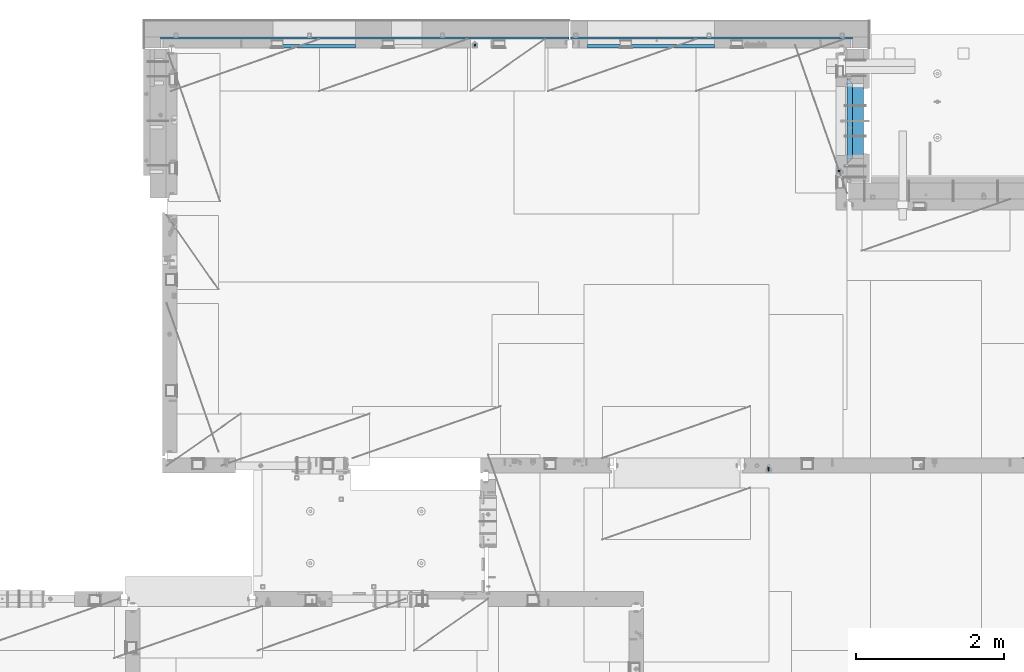
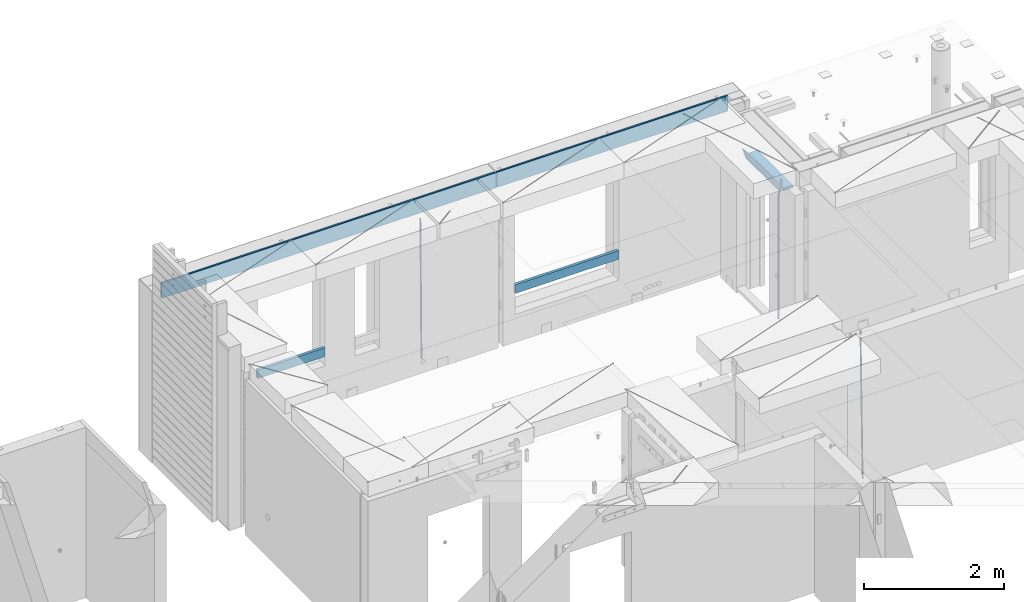
# One storey, part 108 of 309: 10 beams, 4 elements without a shape of their own.
"""IFC2X3 building model written with IfcOpenShell, lengths in millimetres."""

from ifc_helpers import new_model, si_unit, frame, origin_with_axes, place, context, subcontext, project, spatial, faceted_brep, material, type_object, element, aggregate, save


model = new_model("IFC2X3")

# Units and contexts
model_context = context("Model", 3, precision=1e-05, world=origin_with_axes())
body_context = subcontext(model_context, "Body", "Model", "MODEL_VIEW")
ifc_project = project(units=[si_unit("LENGTHUNIT", "METRE", prefix="MILLI"), si_unit("AREAUNIT", "SQUARE_METRE"), si_unit("VOLUMEUNIT", "CUBIC_METRE"), si_unit("MASSUNIT", "GRAM", prefix="KILO"), si_unit("TIMEUNIT", "SECOND"), si_unit("PLANEANGLEUNIT", "RADIAN"), si_unit("SOLIDANGLEUNIT", "STERADIAN"), si_unit("THERMODYNAMICTEMPERATUREUNIT", "DEGREE_CELSIUS"), si_unit("LUMINOUSINTENSITYUNIT", "LUMEN")], contexts=[model_context])

# Site, building, storey
site_placement = place(None, origin_with_axes())
site = spatial("IfcSite", under=ifc_project, at=site_placement, CompositionType="ELEMENT")
building_placement = place(site_placement, origin_with_axes())
building = spatial("IfcBuilding", under=site, at=building_placement, CompositionType="ELEMENT")
storey_placement = place(building_placement, origin_with_axes())
storey = spatial("IfcBuildingStorey", under=building, at=storey_placement, Name="7", CompositionType="ELEMENT", Elevation=0.0)

# Assembly, beams
assembly_1_placement = place(storey_placement, origin_with_axes())
assembly_1 = element("IfcElementAssembly", 1, at=assembly_1_placement, inside=storey, AssemblyPlace="NOTDEFINED", PredefinedType="REINFORCEMENT_UNIT")
ifc_material_1 = material(Name="CONCRETE/C25/30")
beam_type_1 = type_object("IfcBeamType", PredefinedType="NOTDEFINED")
beam_1_placement = place(assembly_1_placement, frame((31494.9951872276, 21060.0002716511, 102140.0), z_axis=(0.0, 0.0, -1.0), x_axis=(0.0, 1.0, 0.0)))
beam_1 = element("IfcBeam", 2, at=beam_1_placement, type_object=beam_type_1, material=ifc_material_1, Name="SK", context=body_context, shape_type="Brep", body=[
    faceted_brep([(70.0000000000164, -35.0, 35.0), (70.0000000000164, 35.0, 35.0), (0.0, -35.0, -35.0), (1079.99961853027, 35.0, 35.0), (1149.99961853027, -35.0, -35.0), (1079.99961853027, -35.0, 35.0)], [[[0, 1, 2]], [[2, 1, 3, 4]], [[0, 2, 4, 5]], [[1, 0, 5, 3]], [[4, 3, 5]]]),
])
beam_type_2 = type_object("IfcBeamType", PredefinedType="NOTDEFINED")
beam_2_placement = place(assembly_1_placement, frame((31494.9951872276, 21130.0002716511, 102080.0), z_axis=(0.0, 0.0, -1.0), x_axis=(0.0, 1.0, 0.0)))
beam_2 = element("IfcBeam", 3, at=beam_2_placement, type_object=beam_type_2, material=ifc_material_1, Name="SK", context=body_context, shape_type="Brep", body=[
    faceted_brep([(0.0, -35.0, -25.0), (43.8457723764295, -35.0, 18.8461538461561), (45.6406441713007, 35.0, 20.6410256410309), (0.0, 35.0, -25.0), (1009.99961853027, 35.0, -25.0), (1009.99961853027, -35.0, -25.0), (966.153464684117, -35.0, 18.8461538461561), (964.358592889246, 35.0, 20.6410256410309)], [[[0, 1, 2, 3]], [[0, 3, 4, 5]], [[1, 0, 5, 6]], [[6, 7, 2, 1]], [[3, 2, 7, 4]], [[6, 5, 4, 7]]]),
])
ifc_material_2 = material(Name="TIMBER")
beam_type_3 = type_object("IfcBeamType", Name="50X150", PredefinedType="NOTDEFINED")
beam_3_placement = place(assembly_1_placement, frame((31604.9951872276, 21130.0002716511, 102080.0), z_axis=(0.0, 0.0, -1.0), x_axis=(0.0, 1.0, 0.0)))
beam_3 = element("IfcBeam", 4, at=beam_3_placement, type_object=beam_type_3, material=ifc_material_2, ObjectType="50X150", context=body_context, shape_type="Brep", body=[
    faceted_brep([(0.0, 75.0, -25.0), (1.81898940354586e-12, 75.0, 25.0), (1009.99961853027, 75.0, 25.0), (1009.99961853027, 75.0, -25.0), (1.81898940354586e-12, -75.0000000000009, 25.0), (1009.99961853027, -75.0, 25.0), (0.0, -75.0, -25.0), (1009.99961853027, -75.0, -25.0)], [[[0, 1, 2, 3]], [[1, 4, 5, 2]], [[4, 6, 7, 5]], [[6, 0, 3, 7]], [[5, 7, 3, 2]], [[6, 4, 1, 0]]]),
])

# Assembly, beam
assembly_2_placement = place(storey_placement, origin_with_axes())
assembly_2 = element("IfcElementAssembly", 5, at=assembly_2_placement, inside=storey, AssemblyPlace="NOTDEFINED", PredefinedType="REINFORCEMENT_UNIT")
ifc_material_3 = material()
beam_type_4 = type_object("IfcBeamType", Name="D20", PredefinedType="NOTDEFINED")
beam_4_placement = place(assembly_2_placement, frame((26430.0000000039, 22654.999995444, 99990.0), z_axis=(-0.000205762999925498, 0.999642804629538, -0.0267249099901004), x_axis=(4.30000201928125e-08, 0.0267249099948059, 0.999642825806181)))
beam_4 = element("IfcBeam", 6, at=beam_4_placement, type_object=beam_type_4, material=ifc_material_3, Name="JM20", ObjectType="D20", context=body_context, shape_type="Brep", body=[
    faceted_brep([(0.0, -10.0, 0.0), (-4.19531716033816e-08, -7.07106781186667, -7.07106781187031), (60.4266690400545, -7.0710677960451, -7.07106780570757), (60.4266690441291, -9.99999998418934, 6.15546014159918e-09), (0.0, 0.0, -10.0), (60.426669036824, 1.58106558956206e-08, -9.99999999384454), (4.196772351861e-08, 7.07106781186303, -7.07106781186667), (60.4266690363438, 7.07106782768096, -7.07106780570757), (0.0, 10.0, 0.0), (60.4266690388904, 10.0000000158179, 6.15182216279209e-09), (4.196772351861e-08, 7.07106781185939, 7.07106781185939), (60.4266690429649, 7.07106782768096, 7.07106781802577), (0.0, 0.0, 10.0), (60.4266690461809, 1.58179318532348e-08, 10.0000000061555), (-4.19531716033816e-08, -7.07106781187031, 7.07106781185939), (60.4266690466611, -7.07106779605238, 7.07106781802213), (61.0378400410118, -7.07106779588503, -7.07106780564936), (60.991799419251, -9.99999998403655, 6.21366780251265e-09), (61.0569027789461, 1.5985278878361e-08, -9.99999999378269), (61.0378209396877, 7.07106782784831, -7.07106780564936), (60.9917724058905, 10.0000000159635, 6.21366780251265e-09), (60.9457317841297, 7.07106782781193, 7.0710678180767), (60.9266690461809, 1.59488990902901e-08, 10.0000000062028), (60.9457508854539, -7.07106779591413, 7.0710678180767), (61.6489592143771, -7.07106614513759, -7.06310863441468), (61.5568818710308, -9.9999984576425, 0.00735959856683621), (61.6870830769039, 1.71821739058942e-06, -9.99179257185824), (61.6489210170112, 7.07106947854481, -7.06310888312146), (61.556827851804, 10.0000015422847, 0.00735924683976918), (61.4647505084577, 7.07106922979438, 7.07782747982128), (61.4266266459163, 1.36643211590126e-06, 10.0065114172685), (61.464788705809, -7.07106639389531, 7.07782772852806), (176.543135720174, -7.07075579406956, -5.56673531796696), (176.451058376813, -9.99968810657447, 1.50373291501455), (176.581259582701, 0.000312069292704109, -8.49541925541052), (176.543097522794, 7.07137982961285, -5.56673556667374), (176.451004357587, 10.00031189336, 1.50373256329476), (176.35892701424, 7.07137958085514, 8.57420079627263), (176.320803151699, 0.000311717507429421, 11.5028847337162), (176.358965211621, -7.07075604281999, 8.57420104497578), (177.098753836006, -7.07075429323595, -5.55949898843028), (176.98362511232, -9.99968666800123, 1.510669025065), (177.146421932586, 0.000313595905026887, -8.48805862247536), (177.098706077581, 7.07138133041735, -5.55949936166144), (176.983557571715, 10.0003133318824, 1.51066849724157), (176.868428848029, 7.07138095712435, 8.58083651073321), (176.820760751449, 0.000313067976094317, 11.5093961447819), (176.868476606425, -7.07075466652896, 8.58083688396073), (177.654312950661, -7.07075204110879, -5.54863964998367), (177.516135294456, -9.99968450931192, 1.52107783331303), (177.711524267797, 0.000315886711177882, -8.47701274570863), (177.654255632195, 7.07138358250813, -5.54864021007961), (177.516054233929, 10.0003154905207, 1.5210770412159), (177.377876577739, 7.0713830223176, 8.59079452451624), (177.320665260588, 0.000315094497636892, 11.5191676202448), (177.377933896176, -7.07075260129932, 8.59079508461218), (299.436796249574, -7.07025836271714, -3.1681962331204), (299.298618593355, -9.99919083092027, 3.90152125031091), (299.494007566798, 0.000809565110102994, -6.09656932889993), (299.436738931283, 7.07187726089978, -3.16819679320906), (299.298537533061, 10.0008091689197, 3.90152045822106), (299.160359876842, 7.07187670072017, 10.9712379416487), (299.103148559603, 0.000808772889286047, 13.8996110374392), (299.160417195119, -7.07025892290039, 10.9712385017483), (299.98743051647, -7.07025613056248, -3.15743315966392), (299.971788958996, -9.99918809853989, 3.91467979818117), (299.993912075952, 0.000811591617093654, -6.08679785393178), (299.987423933868, 7.07187949325817, -3.1574327280432), (299.971753863239, 10.0008119014747, 3.91467990454839), (299.95611230444, 7.07187992653053, 10.9867922621015), (299.949630744944, 0.000812204350950196, 13.9161569563694), (299.956118887014, -7.07025569729012, 10.9867918304735), (300.538107039494, -7.07025785017686, -3.16575821840888), (300.644985195438, -9.99919020432935, 3.90450175465594), (300.493854948218, 0.000810030429420294, -6.09435592770024), (300.538151196495, 7.071877773491, -3.16575855385963), (300.645047642858, 10.0008097955724, 3.90450128024895), (300.751925798773, 7.07187744142357, 10.9747612533101), (300.796177890064, 0.000809560813650023, 13.9033589625978), (300.751881641787, -7.07025818224065, 10.9747615887682), (2293.36490490142, -7.07648090940347, -33.2930642912361), (2293.47178305736, -10.0054132635523, -26.2228043181785), (2293.32065281013, -0.00541302880083094, -36.2216620005347), (2293.36494905842, 7.06565471425711, -33.2930646266868), (2293.47184550477, 9.99458673634581, -26.2228047925819), (2293.57872366071, 7.06565438219332, -19.1525448195243), (2293.62297575199, -0.00541349841296324, -16.2239471102366), (2293.57867950371, -7.0764812414709, -19.1525444840736), (2294.0658245362, -7.07648309818615, -33.3036607065333), (2294.05312277409, -10.0054150789219, -26.2315929392535), (2294.10928714235, -0.00541549149056664, -36.2335844756526), (2294.15805078732, 7.06565223761572, -33.3050546393533), (2294.18355038921, 9.99458451388637, -26.2335642579346), (2294.17084862708, 7.06565253314329, -19.1614964906439), (2294.12738602093, -0.00541507354500936, -16.2315727215355), (2294.07862237596, -7.07648280265857, -19.1601025578348), (2294.76670261032, -7.08562269121467, -33.294332712383), (2294.63442802057, -10.0129954178956, -26.2238563411993), (2294.89787471293, -0.0156988342423574, -36.2230891548279), (2294.95110548967, 7.05531064255774, -33.2944998654275), (2294.89521307347, 9.98530428734011, -26.2240927312887), (2294.76293848372, 7.0579315606592, -19.1536163601049), (2294.63176638114, -0.0119922963167483, -16.2248599176673), (2294.57853560438, -7.08300177311321, -19.1534492070678), (2316.52657204497, -7.36937582653991, -33.0047303660212), (2316.39429745522, -10.2967485532172, -25.9342539948302), (2316.65774414754, -0.299451969567599, -35.9334868084661), (2316.7109749243, 6.7715575072325, -33.0048975190657), (2316.65508250811, 9.70155115201487, -25.9344903849269), (2316.52280791836, 6.7741784253376, -18.8640140137468), (2316.39163581574, -0.295745431634714, -15.9352575713092), (2316.33840503903, -7.36675490843481, -18.863846860706), (2317.16202064224, -7.37766220584308, -32.9962731735213), (2317.05438744847, -10.3053562613532, -25.9254688497131), (2317.23607125619, -0.306993473008333, -35.925789846493), (2317.23316144495, 6.76474808850253, -32.9979477328052), (2317.15499573652, 9.6950321815566, -25.9278370341635), (2317.04736254275, 6.7673381260538, -18.8570327103698), (2316.97331192881, -0.303330606784584, -15.9275160373909), (2316.97622174003, -7.37507216829545, -18.8553581510787), (2317.79752306276, -7.37578610372293, -32.9880110666527), (2317.71453320107, -10.3033876998124, -25.9168792378296), (2317.81444760226, -0.305295583297266, -35.918287695793), (2317.75539265381, 6.76628640723357, -32.9911928173897), (2317.65495180529, 9.69652304524061, -25.9213789128698), (2317.5719619436, 6.76892144914746, -18.8502470840467), (2317.55503740412, -0.301569071270933, -15.9199704549137), (2317.61409235255, -7.3731510618054, -18.847065333317), (2417.8183084176, -7.07752398473531, -31.6906369377139), (2417.73531855589, -10.0051255808248, -24.6195051088798), (2417.83523295709, -0.007033464313281, -34.6209135668432), (2417.77617800863, 7.06454852621755, -31.6938186884508), (2417.67573716014, 9.99478516423187, -24.6240047839383), (2417.59274729842, 7.06718356813872, -17.5528729551006), (2417.57582275895, -0.00330695228694822, -14.6225963259749), (2417.6348777074, -7.07488894281778, -17.5496912043673)], [[[0, 1, 2, 3]], [[1, 4, 5, 2]], [[4, 6, 7, 5]], [[6, 8, 9, 7]], [[8, 10, 11, 9]], [[10, 12, 13, 11]], [[12, 14, 15, 13]], [[14, 0, 3, 15]], [[14, 12, 10, 8, 6, 4, 1, 0]], [[3, 2, 16, 17]], [[2, 5, 18, 16]], [[5, 7, 19, 18]], [[7, 9, 20, 19]], [[9, 11, 21, 20]], [[11, 13, 22, 21]], [[13, 15, 23, 22]], [[15, 3, 17, 23]], [[17, 16, 24, 25]], [[16, 18, 26, 24]], [[18, 19, 27, 26]], [[19, 20, 28, 27]], [[20, 21, 29, 28]], [[21, 22, 30, 29]], [[22, 23, 31, 30]], [[23, 17, 25, 31]], [[25, 24, 32, 33]], [[24, 26, 34, 32]], [[26, 27, 35, 34]], [[27, 28, 36, 35]], [[28, 29, 37, 36]], [[29, 30, 38, 37]], [[30, 31, 39, 38]], [[31, 25, 33, 39]], [[33, 32, 40, 41]], [[32, 34, 42, 40]], [[34, 35, 43, 42]], [[35, 36, 44, 43]], [[36, 37, 45, 44]], [[37, 38, 46, 45]], [[38, 39, 47, 46]], [[39, 33, 41, 47]], [[41, 40, 48, 49]], [[40, 42, 50, 48]], [[42, 43, 51, 50]], [[43, 44, 52, 51]], [[44, 45, 53, 52]], [[45, 46, 54, 53]], [[46, 47, 55, 54]], [[47, 41, 49, 55]], [[49, 48, 56, 57]], [[48, 50, 58, 56]], [[50, 51, 59, 58]], [[51, 52, 60, 59]], [[52, 53, 61, 60]], [[53, 54, 62, 61]], [[54, 55, 63, 62]], [[55, 49, 57, 63]], [[57, 56, 64, 65]], [[56, 58, 66, 64]], [[58, 59, 67, 66]], [[59, 60, 68, 67]], [[60, 61, 69, 68]], [[61, 62, 70, 69]], [[62, 63, 71, 70]], [[63, 57, 65, 71]], [[65, 64, 72, 73]], [[64, 66, 74, 72]], [[66, 67, 75, 74]], [[67, 68, 76, 75]], [[68, 69, 77, 76]], [[69, 70, 78, 77]], [[70, 71, 79, 78]], [[71, 65, 73, 79]], [[73, 72, 80, 81]], [[72, 74, 82, 80]], [[74, 75, 83, 82]], [[75, 76, 84, 83]], [[76, 77, 85, 84]], [[77, 78, 86, 85]], [[78, 79, 87, 86]], [[79, 73, 81, 87]], [[81, 80, 88, 89]], [[80, 82, 90, 88]], [[82, 83, 91, 90]], [[83, 84, 92, 91]], [[84, 85, 93, 92]], [[85, 86, 94, 93]], [[86, 87, 95, 94]], [[87, 81, 89, 95]], [[89, 88, 96, 97]], [[88, 90, 98, 96]], [[90, 91, 99, 98]], [[91, 92, 100, 99]], [[92, 93, 101, 100]], [[93, 94, 102, 101]], [[94, 95, 103, 102]], [[95, 89, 97, 103]], [[97, 96, 104, 105]], [[96, 98, 106, 104]], [[98, 99, 107, 106]], [[99, 100, 108, 107]], [[100, 101, 109, 108]], [[101, 102, 110, 109]], [[102, 103, 111, 110]], [[103, 97, 105, 111]], [[105, 104, 112, 113]], [[104, 106, 114, 112]], [[106, 107, 115, 114]], [[107, 108, 116, 115]], [[108, 109, 117, 116]], [[109, 110, 118, 117]], [[110, 111, 119, 118]], [[111, 105, 113, 119]], [[113, 112, 120, 121]], [[112, 114, 122, 120]], [[114, 115, 123, 122]], [[115, 116, 124, 123]], [[116, 117, 125, 124]], [[117, 118, 126, 125]], [[118, 119, 127, 126]], [[119, 113, 121, 127]], [[121, 120, 128, 129]], [[120, 122, 130, 128]], [[122, 123, 131, 130]], [[123, 124, 132, 131]], [[124, 125, 133, 132]], [[125, 126, 134, 133]], [[126, 127, 135, 134]], [[127, 121, 129, 135]], [[130, 131, 132, 133, 134, 135, 129, 128]]]),
])

assembly_3_placement = place(storey_placement, origin_with_axes())
assembly_3 = element("IfcElementAssembly", 7, at=assembly_3_placement, inside=storey, AssemblyPlace="NOTDEFINED", PredefinedType="REINFORCEMENT_UNIT")
beam_5_placement = place(assembly_3_placement, frame((30400.0000000039, 16915.0002418615, 99990.0), z_axis=(-0.000205762999925498, 0.999642804629538, -0.0267249099901004), x_axis=(4.30000201928125e-08, 0.0267249099948059, 0.999642825806181)))
beam_5 = element("IfcBeam", 8, at=beam_5_placement, type_object=beam_type_4, material=ifc_material_3, Name="JM20", ObjectType="D20", context=body_context, shape_type="Brep", body=[
    faceted_brep([(0.0, -10.0, 0.0), (-4.19531716033816e-08, -7.07106781186667, -7.07106781187031), (60.4266690400545, -7.0710677960451, -7.07106780570757), (60.4266690441291, -9.99999998418934, 6.15546014159918e-09), (0.0, 0.0, -10.0), (60.426669036824, 1.58106558956206e-08, -9.99999999384454), (4.196772351861e-08, 7.07106781186303, -7.07106781186667), (60.4266690363438, 7.07106782768096, -7.07106780570757), (0.0, 10.0, 0.0), (60.4266690388904, 10.0000000158179, 6.15182216279209e-09), (4.196772351861e-08, 7.07106781185939, 7.07106781185939), (60.4266690429649, 7.07106782768096, 7.07106781802577), (0.0, 0.0, 10.0), (60.4266690461809, 1.58179318532348e-08, 10.0000000061555), (-4.19531716033816e-08, -7.07106781187031, 7.07106781185939), (60.4266690466611, -7.07106779605238, 7.07106781802213), (61.0378400410118, -7.07106779588503, -7.07106780564936), (60.991799419251, -9.99999998403655, 6.21366780251265e-09), (61.0569027789461, 1.5985278878361e-08, -9.99999999378269), (61.0378209396877, 7.07106782784831, -7.07106780564936), (60.9917724058905, 10.0000000159635, 6.21366780251265e-09), (60.9457317841297, 7.07106782781193, 7.0710678180767), (60.9266690461809, 1.59488990902901e-08, 10.0000000062028), (60.9457508854539, -7.07106779591413, 7.0710678180767), (61.6489592143771, -7.07106614513759, -7.06310863441468), (61.5568818710308, -9.9999984576425, 0.00735959856683621), (61.6870830769039, 1.71821739058942e-06, -9.99179257185824), (61.6489210170112, 7.07106947854481, -7.06310888312146), (61.556827851804, 10.0000015422847, 0.00735924683976918), (61.4647505084577, 7.07106922979438, 7.07782747982128), (61.4266266459163, 1.36643211590126e-06, 10.0065114172685), (61.464788705809, -7.07106639389531, 7.07782772852806), (176.543135720174, -7.07075579406956, -5.56673531796696), (176.451058376813, -9.99968810657447, 1.50373291501455), (176.581259582701, 0.000312069292704109, -8.49541925541052), (176.543097522794, 7.07137982961285, -5.56673556667374), (176.451004357587, 10.00031189336, 1.50373256329476), (176.35892701424, 7.07137958085514, 8.57420079627263), (176.320803151699, 0.000311717507429421, 11.5028847337162), (176.358965211621, -7.07075604281999, 8.57420104497578), (177.098753836006, -7.07075429323595, -5.55949898843028), (176.98362511232, -9.99968666800123, 1.510669025065), (177.146421932586, 0.000313595905026887, -8.48805862247536), (177.098706077581, 7.07138133041735, -5.55949936166144), (176.983557571715, 10.0003133318824, 1.51066849724157), (176.868428848029, 7.07138095712435, 8.58083651073321), (176.820760751449, 0.000313067976094317, 11.5093961447819), (176.868476606425, -7.07075466652896, 8.58083688396073), (177.654312950661, -7.07075204110879, -5.54863964998367), (177.516135294456, -9.99968450931192, 1.52107783331303), (177.711524267797, 0.000315886711177882, -8.47701274570863), (177.654255632195, 7.07138358250813, -5.54864021007961), (177.516054233929, 10.0003154905207, 1.5210770412159), (177.377876577739, 7.0713830223176, 8.59079452451624), (177.320665260588, 0.000315094497636892, 11.5191676202448), (177.377933896176, -7.07075260129932, 8.59079508461218), (299.499456785634, -7.07025810522464, -3.16697112782276), (299.361279129444, -9.99919057342777, 3.90274635547394), (299.556668102785, 0.000809822595329024, -6.09534422354773), (299.499399467197, 7.07187751838501, -3.1669716879187), (299.361198068917, 10.0008094264049, 3.90274556338045), (299.223020412712, 7.07187695819448, 10.9724630466735), (299.165809095575, 0.000809030381788034, 13.9008361423985), (299.223077731163, -7.07025866542244, 10.9724636067695), (300.03174732349, -7.07025594743027, -3.15656661289177), (299.971788958996, -9.99918809853989, 3.91467979818117), (300.056572611924, 0.000811849109595641, -6.08557274808481), (300.031722507032, 7.07187967631762, -3.15656653768019), (299.971753863239, 10.0008119014747, 3.91467990454839), (299.91179549876, 7.07187975035777, 10.9859263156177), (299.886970210311, 0.000811953817901667, 13.9149324508144), (299.911820315203, -7.0702558733974, 10.9859262404061), (300.564137759997, -7.07025623699155, -3.15794273276697), (300.582413367199, -9.99918843065097, 3.91310145956595), (300.556570941641, 0.000811577163403854, -6.0868651410201), (300.564145451674, 7.07187938674906, -3.15794274158179), (300.582424244858, 10.0008115693345, 3.91310144710224), (300.600699852032, 7.07187937566778, 10.9841456394352), (300.608266670402, 0.000811561512819026, 13.9130680476919), (300.600692160384, -7.07025624805829, 10.98414564825), (2294.16589219622, -7.0713405251372, -8.31099358700158), (2294.1841678034, -10.0002727187966, -1.23994939466866), (2294.15832537785, -0.000272710982244462, -11.2399159952547), (2294.16589988787, 7.07079509858886, -8.31099359582004), (2294.18417868105, 9.99972728118883, -1.23994940713601), (2294.20245428824, 7.07079508752213, 5.83109478519327), (2294.2100211066, -0.00027272663282929, 8.76001719345368), (2294.20244659658, -7.07134053620393, 5.83109479401173), (2294.7782683276, -7.07134085819416, -8.31257645345977), (2294.72126025338, -10.000273010919, -1.24133766827799), (2294.84007459224, -0.000273081772320438, -11.2416781768807), (2294.87047377572, 7.07079471537872, -8.31281477453012), (2294.85165844864, 9.9997269181622, -1.24167470516841), (2294.7946503744, 7.07079476544459, 5.82956408001337), (2294.73284410976, -0.000273010977252852, 8.75866580342336), (2294.7024449263, -7.07134080815013, 5.82980240107645), (2295.39054023061, -7.0793250091956, -8.30442771922026), (2295.25826128852, -10.0072756143927, -1.23419071494573), (2295.52170777075, -0.00916171800054144, -11.2326063125765), (2295.57492774284, 7.06160849139269, -8.30343918807193), (2295.51902460904, 9.99102432676591, -1.23279272078435), (2295.38674566693, 7.06307372157607, 5.83744428349019), (2295.25557812679, -0.0070895696117077, 8.76562287684646), (2295.20235815471, -7.07785977901949, 5.83645575234186), (2317.1947101649, -7.36365585014573, -8.01423575520312), (2317.06243122277, -10.2916064553428, -0.94399875092131), (2317.32587770502, -0.293492558957951, -10.9424143485521), (2317.37909767711, 6.77727765044983, -8.01324722405116), (2317.32319454331, 9.70669348581578, -0.942600756767206), (2317.1909156012, 6.77874288063322, 6.12763624751096), (2317.05974806109, -0.291420410569117, 9.0558148408636), (2317.00652808898, -7.36219061996962, 6.12664771636264), (2317.83015404257, -7.37194216843636, -8.00577862486898), (2317.72252095213, -10.300214160583, -0.935213608652703), (2317.90419832576, -0.301033978277701, -10.9347174723516), (2317.90127966482, 6.77046829039318, -8.00629749759901), (2317.82310777172, 9.70017451494641, -0.935947405505431), (2317.71547468127, 6.77190252279979, 6.13461761071085), (2317.64143039809, -0.29900566735887, 9.06355645819713), (2317.64434905903, -7.37050793602975, 6.13513648344451), (2318.46565174212, -7.3700661537805, -7.99751648408346), (2318.38266643914, -10.2982456018653, -0.926623872735945), (2318.48256818345, -0.299336209594912, -10.9272153854981), (2318.42350634121, 6.77200652527245, -7.99954269419686), (2318.32306384158, 9.70166538090416, -0.929489366557391), (2318.2400785386, 6.77348593281204, 6.14140324480104), (2318.22316209726, -0.297244011366274, 9.07110214621207), (2318.2822239395, -7.36858674623363, 6.1434294549108), (2418.48643733139, -7.07180401323421, -6.70013846199799), (2418.4034520284, -9.99998346132634, 0.370754149349523), (2418.5033537727, -0.00107406904135132, -9.62983736341266), (2418.44429193046, 7.07026866581873, -6.70216467211139), (2418.34384943081, 9.99992752145772, 0.367888655531715), (2418.26086412782, 7.0717480733656, 7.43878126688651), (2418.24394768651, 0.00101812917273492, 10.3684801682975), (2418.30300952874, -7.07032460568735, 7.44080747699627)], [[[0, 1, 2, 3]], [[1, 4, 5, 2]], [[4, 6, 7, 5]], [[6, 8, 9, 7]], [[8, 10, 11, 9]], [[10, 12, 13, 11]], [[12, 14, 15, 13]], [[14, 0, 3, 15]], [[14, 12, 10, 8, 6, 4, 1, 0]], [[3, 2, 16, 17]], [[2, 5, 18, 16]], [[5, 7, 19, 18]], [[7, 9, 20, 19]], [[9, 11, 21, 20]], [[11, 13, 22, 21]], [[13, 15, 23, 22]], [[15, 3, 17, 23]], [[17, 16, 24, 25]], [[16, 18, 26, 24]], [[18, 19, 27, 26]], [[19, 20, 28, 27]], [[20, 21, 29, 28]], [[21, 22, 30, 29]], [[22, 23, 31, 30]], [[23, 17, 25, 31]], [[25, 24, 32, 33]], [[24, 26, 34, 32]], [[26, 27, 35, 34]], [[27, 28, 36, 35]], [[28, 29, 37, 36]], [[29, 30, 38, 37]], [[30, 31, 39, 38]], [[31, 25, 33, 39]], [[33, 32, 40, 41]], [[32, 34, 42, 40]], [[34, 35, 43, 42]], [[35, 36, 44, 43]], [[36, 37, 45, 44]], [[37, 38, 46, 45]], [[38, 39, 47, 46]], [[39, 33, 41, 47]], [[41, 40, 48, 49]], [[40, 42, 50, 48]], [[42, 43, 51, 50]], [[43, 44, 52, 51]], [[44, 45, 53, 52]], [[45, 46, 54, 53]], [[46, 47, 55, 54]], [[47, 41, 49, 55]], [[49, 48, 56, 57]], [[48, 50, 58, 56]], [[50, 51, 59, 58]], [[51, 52, 60, 59]], [[52, 53, 61, 60]], [[53, 54, 62, 61]], [[54, 55, 63, 62]], [[55, 49, 57, 63]], [[57, 56, 64, 65]], [[56, 58, 66, 64]], [[58, 59, 67, 66]], [[59, 60, 68, 67]], [[60, 61, 69, 68]], [[61, 62, 70, 69]], [[62, 63, 71, 70]], [[63, 57, 65, 71]], [[65, 64, 72, 73]], [[64, 66, 74, 72]], [[66, 67, 75, 74]], [[67, 68, 76, 75]], [[68, 69, 77, 76]], [[69, 70, 78, 77]], [[70, 71, 79, 78]], [[71, 65, 73, 79]], [[73, 72, 80, 81]], [[72, 74, 82, 80]], [[74, 75, 83, 82]], [[75, 76, 84, 83]], [[76, 77, 85, 84]], [[77, 78, 86, 85]], [[78, 79, 87, 86]], [[79, 73, 81, 87]], [[81, 80, 88, 89]], [[80, 82, 90, 88]], [[82, 83, 91, 90]], [[83, 84, 92, 91]], [[84, 85, 93, 92]], [[85, 86, 94, 93]], [[86, 87, 95, 94]], [[87, 81, 89, 95]], [[89, 88, 96, 97]], [[88, 90, 98, 96]], [[90, 91, 99, 98]], [[91, 92, 100, 99]], [[92, 93, 101, 100]], [[93, 94, 102, 101]], [[94, 95, 103, 102]], [[95, 89, 97, 103]], [[97, 96, 104, 105]], [[96, 98, 106, 104]], [[98, 99, 107, 106]], [[99, 100, 108, 107]], [[100, 101, 109, 108]], [[101, 102, 110, 109]], [[102, 103, 111, 110]], [[103, 97, 105, 111]], [[105, 104, 112, 113]], [[104, 106, 114, 112]], [[106, 107, 115, 114]], [[107, 108, 116, 115]], [[108, 109, 117, 116]], [[109, 110, 118, 117]], [[110, 111, 119, 118]], [[111, 105, 113, 119]], [[113, 112, 120, 121]], [[112, 114, 122, 120]], [[114, 115, 123, 122]], [[115, 116, 124, 123]], [[116, 117, 125, 124]], [[117, 118, 126, 125]], [[118, 119, 127, 126]], [[119, 113, 121, 127]], [[121, 120, 128, 129]], [[120, 122, 130, 128]], [[122, 123, 131, 130]], [[123, 124, 132, 131]], [[124, 125, 133, 132]], [[125, 126, 134, 133]], [[126, 127, 135, 134]], [[127, 121, 129, 135]], [[130, 131, 132, 133, 134, 135, 129, 128]]]),
])
aggregate(assembly_3, [beam_5])

# Beam
beam_6_placement = place(assembly_1_placement, frame((31384.9951872298, 20959.9999999916, 102407.5), z_axis=(-0.999999913638316, 0.000415599999849952, 0.0), x_axis=(0.0, 0.0, -1.0)))
beam_6 = element("IfcBeam", 9, at=beam_6_placement, type_object=beam_type_4, material=ifc_material_3, Name="JM20", ObjectType="D20", context=body_context, shape_type="Brep", body=[
    faceted_brep([(0.0, -10.0, 0.0), (-4.19531716033816e-08, -7.07106781186667, -7.07106781187031), (113.248091332178, -7.0710684840451, -7.0710678117357), (113.248091314759, -10.0000006713562, -2.51020537689328e-10), (0.0, 0.0, -10.0), (113.248091374131, -6.72178430249915e-07, -9.99999999986903), (4.196772351861e-08, 7.07106781186303, -7.07106781186667), (113.248091416113, 7.07106713968824, -7.07106781173934), (0.0, 10.0, 0.0), (113.248091433488, 9.99999932782521, 1.30967237055302e-10), (4.196772351861e-08, 7.07106781185939, 7.07106781185939), (113.248091416113, 7.0710671396846, 7.071067811994), (0.0, 0.0, 10.0), (113.248091374131, -6.72174792271107e-07, 10.0000000001273), (-4.19531716033816e-08, -7.07106781187031, 7.07106781185939), (113.248091332178, -7.0710684840451, 7.071067811994), (130.699843527167, -7.06993249763036, -4.33745683788584), (128.538066582521, -9.99900540317321, 2.39499413731755), (131.594536475241, 0.00119355250353692, -7.12624594330919), (130.698046432328, 7.07220300913468, -4.33773834422391), (128.535525107087, 10.0009944322555, 2.39459602660281), (126.373748162892, 7.07192152754578, 9.1270470011732), (125.479055214906, 0.000795477419160306, 11.9158361066184), (126.37554525779, -7.07021397921199, 9.12732850753673), (240.336258550378, -7.05529970173666, 30.8729495437874), (238.174481606227, -9.98437260450009, 37.6054005176375), (241.230951498423, 0.0158263482953771, 28.0841604381058), (240.334461455612, 7.0868358050102, 30.8726680369582), (238.171940130502, 10.0156272283348, 37.6050024077231), (236.010163186409, 7.08655432384694, 44.3374533824244), (235.115470238379, 0.0154282738185429, 47.1262424881097), (236.011960281176, -7.05558118289991, 44.3377348892536), (253.461915329972, -7.05444528127919, 32.9289287376414), (253.46191532613, -9.98337746617108, 39.9999965521893), (253.461915339081, 0.0166225284556276, 29.9999965443676), (253.461915348205, 7.08769034247234, 32.9289287273205), (253.461915352003, 10.0166225357716, 39.9999965370152), (253.461915348293, 7.08769035281148, 47.0710643509774), (253.461915339183, 0.0166225430875784, 49.999996544273), (253.46191533003, -7.05444527093641, 47.0710643613093), (2417.50000002384, -7.0544364694706, 32.9289287374122), (2417.5000000337, -9.98336865393321, 39.9999965507959), (2417.49999999997, 0.0166313408753922, 29.9999965456082), (2417.49999997609, 7.08769915426274, 32.9289287300708), (2417.4999999662, 10.0166313460668, 39.9999965404204), (2417.49999997608, 7.08769916160054, 47.0710643538114), (2417.49999999994, 0.0166313512581837, 49.9999965456154), (2417.50000002382, -7.05443646212916, 47.0710643611455)], [[[0, 1, 2, 3]], [[1, 4, 5, 2]], [[4, 6, 7, 5]], [[6, 8, 9, 7]], [[8, 10, 11, 9]], [[10, 12, 13, 11]], [[12, 14, 15, 13]], [[14, 0, 3, 15]], [[14, 12, 10, 8, 6, 4, 1, 0]], [[3, 2, 16, 17]], [[2, 5, 18, 16]], [[5, 7, 19, 18]], [[7, 9, 20, 19]], [[9, 11, 21, 20]], [[11, 13, 22, 21]], [[13, 15, 23, 22]], [[15, 3, 17, 23]], [[17, 16, 24, 25]], [[16, 18, 26, 24]], [[18, 19, 27, 26]], [[19, 20, 28, 27]], [[20, 21, 29, 28]], [[21, 22, 30, 29]], [[22, 23, 31, 30]], [[23, 17, 25, 31]], [[25, 24, 32, 33]], [[24, 26, 34, 32]], [[26, 27, 35, 34]], [[27, 28, 36, 35]], [[28, 29, 37, 36]], [[29, 30, 38, 37]], [[30, 31, 39, 38]], [[31, 25, 33, 39]], [[33, 32, 40, 41]], [[32, 34, 42, 40]], [[34, 35, 43, 42]], [[35, 36, 44, 43]], [[36, 37, 45, 44]], [[37, 38, 46, 45]], [[38, 39, 47, 46]], [[39, 33, 41, 47]], [[42, 43, 44, 45, 46, 47, 41, 40]]]),
])

aggregate(assembly_1, [beam_6, beam_1, beam_2, beam_3])

ifc_material_4 = material(Name="TIMBER/T24")
beam_type_5 = type_object("IfcBeamType", PredefinedType="NOTDEFINED")
beam_7_placement = place(assembly_2_placement, frame((24815.0002989914, 22644.9998418812, 100685.0), z_axis=(0.0, 0.0, 1.0), x_axis=(-1.0, 3.00000001838171e-08, 0.0)))
beam_7 = element("IfcBeam", 10, at=beam_7_placement, type_object=beam_type_5, material=ifc_material_4, context=body_context, shape_type="Brep", body=[
    faceted_brep([(-3.63797880709171e-12, 24.9999999999964, -75.0), (-3.63797880709171e-12, 24.9999999999964, 75.0), (1110.0, 24.9999999999964, 75.0), (1110.0, 24.9999999999964, -75.0), (0.0, -25.0000000000073, 75.0), (1110.0, -25.0000000000073, 75.0), (0.0, -25.0000000000073, -75.0), (1110.0, -25.0000000000073, -75.0)], [[[0, 1, 2, 3]], [[1, 4, 5, 2]], [[4, 6, 7, 5]], [[6, 0, 3, 7]], [[5, 7, 3, 2]], [[6, 4, 1, 0]]]),
])

# Assembly, beams
assembly_4_placement = place(storey_placement, origin_with_axes())
assembly_4 = element("IfcElementAssembly", 11, at=assembly_4_placement, inside=storey, AssemblyPlace="NOTDEFINED", PredefinedType="REINFORCEMENT_UNIT")
beam_8_placement = place(assembly_4_placement, frame((29665.0002980493, 22644.9998418812, 100685.0), z_axis=(0.0, 0.0, 1.0), x_axis=(-1.0, 3.00000001838171e-08, 0.0)))
beam_8 = element("IfcBeam", 12, at=beam_8_placement, type_object=beam_type_5, material=ifc_material_4, context=body_context, shape_type="Brep", body=[
    faceted_brep([(-3.63797880709171e-12, 24.9999999999964, -75.0), (-3.63797880709171e-12, 24.9999999999964, 75.0), (1710.0, 25.0, 75.0), (1710.0, 25.0, -75.0), (0.0, -25.0000000000073, 75.0), (1709.99999999999, -25.0, 75.0), (0.0, -25.0000000000073, -75.0), (1709.99999999999, -25.0, -75.0)], [[[0, 1, 2, 3]], [[1, 4, 5, 2]], [[4, 6, 7, 5]], [[6, 0, 3, 7]], [[5, 7, 3, 2]], [[6, 4, 1, 0]]]),
])
beam_type_6 = type_object("IfcBeamType", Name="270X30", PredefinedType="NOTDEFINED")
beam_9_placement = place(assembly_4_placement, frame((31535.0, 22755.0, 102605.0), z_axis=(0.0, 0.0, 1.0), x_axis=(-1.0, 3.00000001838171e-08, 0.0)))
beam_9 = element("IfcBeam", 13, at=beam_9_placement, type_object=beam_type_6, material=ifc_material_1, ObjectType="270X30", context=body_context, shape_type="Brep", body=[
    faceted_brep([(0.0, 15.0, -135.0), (0.0, 15.0, 135.0), (3815.00000000003, 15.0, 135.0), (3815.00000000003, 15.0, -135.0), (0.0, -15.0, 135.0), (3815.00000000003, -15.0, 135.0), (0.0, -15.0, -135.0), (3815.00000000003, -15.0, -135.0)], [[[0, 1, 2, 3]], [[1, 4, 5, 2]], [[4, 6, 7, 5]], [[6, 0, 3, 7]], [[5, 7, 3, 2]], [[6, 4, 1, 0]]]),
])
aggregate(assembly_4, [beam_9, beam_8])

# Beam
beam_10_placement = place(assembly_2_placement, frame((27705.0, 22755.0, 102605.0), z_axis=(0.0, 0.0, 1.0), x_axis=(-1.0, 3.00000001838171e-08, 0.0)))
beam_10 = element("IfcBeam", 14, at=beam_10_placement, type_object=beam_type_6, material=ifc_material_1, ObjectType="270X30", context=body_context, shape_type="Brep", body=[
    faceted_brep([(0.0, 15.0, -135.0), (0.0, 15.0, 135.0), (5520.00000000003, 15.0, 135.0), (5520.00000000003, 15.0, -135.0), (0.0, -15.0, 135.0), (5520.00000000003, -15.0, 135.0), (0.0, -15.0, -135.0), (5520.00000000003, -15.0, -135.0)], [[[0, 1, 2, 3]], [[1, 4, 5, 2]], [[4, 6, 7, 5]], [[6, 0, 3, 7]], [[5, 7, 3, 2]], [[6, 4, 1, 0]]]),
])

aggregate(assembly_2, [beam_4, beam_7, beam_10])

save(model, "model.ifc")
